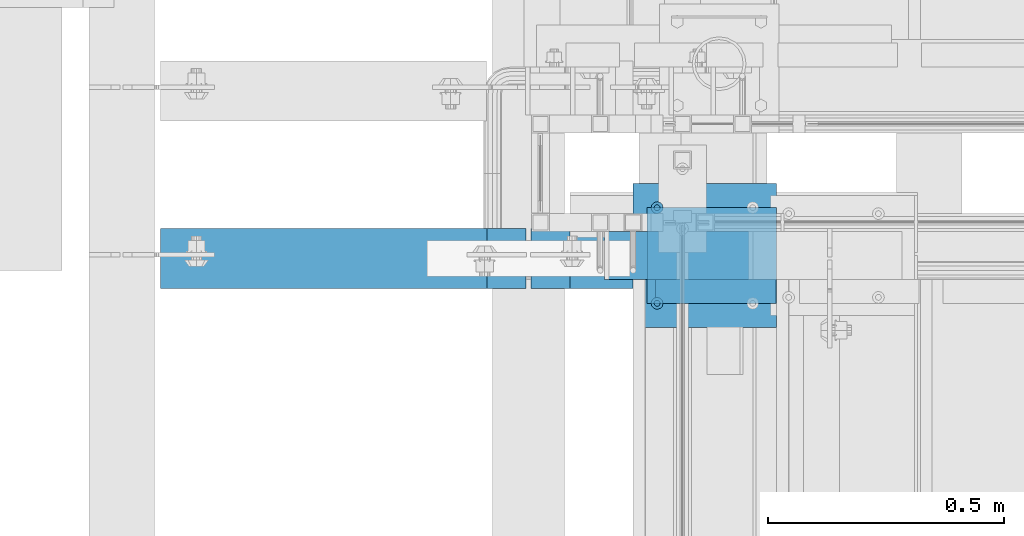
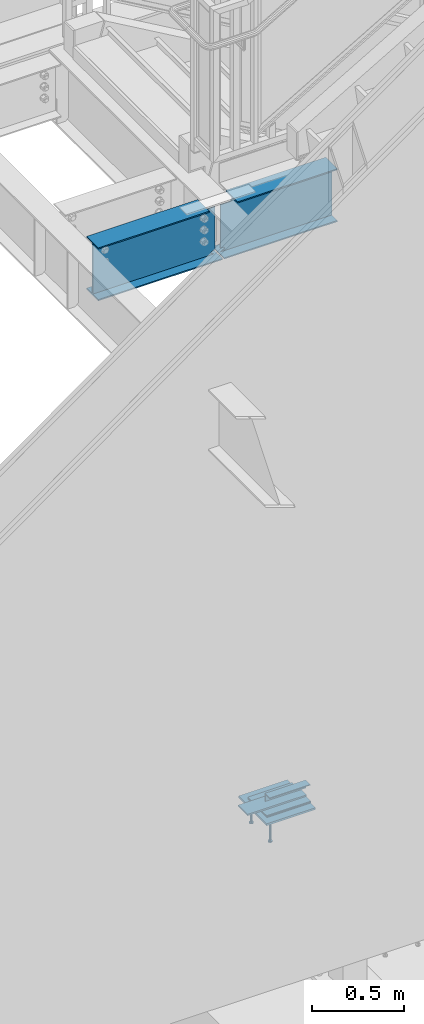
# One storey, part 910 of 1179: 10 beams, 7 elements without a shape of their own.
"""IFC2X3 building model written with IfcOpenShell, lengths in millimetres."""

from ifc_helpers import new_model, si_unit, frame, origin_with_axes, place, context, subcontext, project, spatial, faceted_brep, material, type_object, element, aggregate, save


model = new_model("IFC2X3")

# Units and contexts
model_context = context("Model", 3, precision=1e-05, world=origin_with_axes())
body_context = subcontext(model_context, "Body", "Model", "MODEL_VIEW")
ifc_project = project(units=[si_unit("LENGTHUNIT", "METRE", prefix="MILLI"), si_unit("AREAUNIT", "SQUARE_METRE"), si_unit("VOLUMEUNIT", "CUBIC_METRE"), si_unit("MASSUNIT", "GRAM", prefix="KILO"), si_unit("TIMEUNIT", "SECOND"), si_unit("PLANEANGLEUNIT", "RADIAN"), si_unit("SOLIDANGLEUNIT", "STERADIAN"), si_unit("THERMODYNAMICTEMPERATUREUNIT", "DEGREE_CELSIUS"), si_unit("LUMINOUSINTENSITYUNIT", "LUMEN")], contexts=[model_context])

# Site, building, storey
site_placement = place(None, origin_with_axes())
site = spatial("IfcSite", under=ifc_project, at=site_placement, CompositionType="ELEMENT")
building_placement = place(site_placement, origin_with_axes())
building = spatial("IfcBuilding", under=site, at=building_placement, Name="Undefined", CompositionType="ELEMENT")
storey_placement = place(building_placement, origin_with_axes())
storey = spatial("IfcBuildingStorey", under=building, at=storey_placement, Name="Undefined", CompositionType="ELEMENT", Elevation=0.0)

# Assembly, beam
assembly_1_placement = place(storey_placement, origin_with_axes())
assembly_1 = element("IfcElementAssembly", 1, at=assembly_1_placement, inside=storey, Name="STAIR", AssemblyPlace="NOTDEFINED", PredefinedType="RIGID_FRAME")
ifc_material_1 = material(Name="STEEL/A36")
beam_type_1 = type_object("IfcBeamType", Name="L2X2X3/16", PredefinedType="NOTDEFINED")
beam_1_placement = place(assembly_1_placement, frame((19548.8678269992, 39325.550000005, 97.6973832879577), z_axis=(0.0, -1.0, 0.0), x_axis=(1.0, 0.0, 0.0)))
beam_1 = element("IfcBeam", 2, at=beam_1_placement, type_object=beam_type_1, material=ifc_material_1, Name="ANGLE", ObjectType="L2X2X3/16", context=body_context, shape_type="Brep", body=[
    faceted_brep([(0.0, 25.3999999999996, -25.4000000000015), (0.0, 25.3999999999996, 25.4000000000015), (254.0, 25.3999999999996, 25.4000000000001), (254.0, 25.3999999999996, -25.4000000000001), (0.0, 20.6374999999998, 25.4000000000015), (254.0, 20.6374999999998, 25.4000000000001), (0.0, 20.6374999999998, -20.6374999999971), (254.0, 20.6374999999998, -20.6374999999998), (0.0, -25.3999999999996, -20.6374999999971), (254.0, -25.3999999999996, -20.6374999999998), (0.0, -25.3999999999996, -25.4000000000015), (254.0, -25.3999999999996, -25.4000000000001)], [[[0, 1, 2, 3]], [[1, 4, 5, 2]], [[4, 6, 7, 5]], [[6, 8, 9, 7]], [[8, 10, 11, 9]], [[10, 0, 3, 11]], [[5, 7, 9, 11, 3, 2]], [[10, 8, 6, 4, 1, 0]]]),
])

# Assembly, beams
assembly_2_placement = place(storey_placement, origin_with_axes())
assembly_2 = element("IfcElementAssembly", 3, at=assembly_2_placement, inside=storey, Name="EMBED", AssemblyPlace="NOTDEFINED", PredefinedType="RIGID_FRAME")
ifc_material_2 = material(Name="STEEL/A108")
beam_type_2 = type_object("IfcBeamType", Name="STUD_1/2-DIA", PredefinedType="NOTDEFINED")
beam_2_placement = place(assembly_2_placement, frame((19551.6500003795, 39300.1499999899, -12.6999999999998), z_axis=(0.0, -1.0, 0.0), x_axis=(0.0, 0.0, -1.0)))
beam_2 = element("IfcBeam", 4, at=beam_2_placement, type_object=beam_type_2, material=ifc_material_2, Name="SHEAR STUD", ObjectType="STUD_1/2-DIA", context=body_context, shape_type="Brep", body=[
    faceted_brep([(0.0, -3.1800000667572, 5.5), (0.0, -5.5, 3.1800000667572), (141.732, -5.5, 3.1800000667572), (141.732, -3.1800000667572, 5.5), (0.0, -6.34999999999854, 0.0), (141.732, -6.34999990463257, 0.0), (0.0, -5.5, -3.1800000667572), (141.732, -5.5, -3.1800000667572), (0.0, -3.1800000667572, -5.5), (141.732, -3.1800000667572, -5.5), (0.0, 0.0, -6.34999999999991), (141.732, 0.0, -6.34999990463257), (0.0, 3.1800000667572, -5.5), (141.732, 3.1800000667572, -5.5), (0.0, 5.5, -3.1800000667572), (141.732, 5.5, -3.1800000667572), (0.0, 6.34999999999854, 0.0), (141.732, 6.34999990463257, 0.0), (0.0, 5.5, 3.1800000667572), (141.732, 5.5, 3.1800000667572), (0.0, 3.1800000667572, 5.5), (141.732, 3.1800000667572, 5.5), (0.0, 0.0, 6.34999999999991), (141.732, 0.0, 6.34999990463257), (144.78, -10.9899997711182, 6.34999990463257), (144.78, -6.34000015258789, 10.9899997711182), (144.78, -12.6999998092651, 0.0), (144.78, -10.9899997711182, -6.34999990463257), (144.78, -6.34000015258789, -10.9899997711182), (144.78, 0.0, -12.6899995803833), (144.78, 6.34000015258789, -10.9899997711182), (144.78, 10.9899997711182, -6.34999990463257), (144.78, 12.6999998092651, 0.0), (144.78, 10.9899997711182, 6.34999990463257), (144.78, 6.34000015258789, 10.9899997711182), (144.78, 0.0, 12.6899995803833), (152.4, -10.9899997711182, 6.34999990463257), (152.4, -6.34000015258789, 10.9899997711182), (152.4, -12.6999998092651, 0.0), (152.4, -10.9899997711182, -6.34999990463257), (152.4, -6.34000015258789, -10.9899997711182), (152.4, 0.0, -12.6899995803833), (152.4, 6.34000015258789, -10.9899997711182), (152.4, 10.9899997711182, -6.34999990463257), (152.4, 12.6999998092651, 0.0), (152.4, 10.9899997711182, 6.34999990463257), (152.4, 6.34000015258789, 10.9899997711182), (152.4, 0.0, 12.6899995803833)], [[[0, 1, 2, 3]], [[1, 4, 5, 2]], [[4, 6, 7, 5]], [[6, 8, 9, 7]], [[8, 10, 11, 9]], [[10, 12, 13, 11]], [[12, 14, 15, 13]], [[14, 16, 17, 15]], [[16, 18, 19, 17]], [[18, 20, 21, 19]], [[20, 22, 23, 21]], [[22, 0, 3, 23]], [[22, 20, 18, 16, 14, 12, 10, 8, 6, 4, 1, 0]], [[3, 2, 24, 25]], [[2, 5, 26, 24]], [[5, 7, 27, 26]], [[7, 9, 28, 27]], [[9, 11, 29, 28]], [[11, 13, 30, 29]], [[13, 15, 31, 30]], [[15, 17, 32, 31]], [[17, 19, 33, 32]], [[19, 21, 34, 33]], [[21, 23, 35, 34]], [[23, 3, 25, 35]], [[25, 24, 36, 37]], [[24, 26, 38, 36]], [[26, 27, 39, 38]], [[27, 28, 40, 39]], [[28, 29, 41, 40]], [[29, 30, 42, 41]], [[30, 31, 43, 42]], [[31, 32, 44, 43]], [[32, 33, 45, 44]], [[33, 34, 46, 45]], [[34, 35, 47, 46]], [[35, 25, 37, 47]], [[38, 39, 40, 41, 42, 43, 44, 45, 46, 47, 37, 36]]]),
])
beam_3_placement = place(assembly_2_placement, frame((19551.6500003795, 39503.3499999899, -12.6999999999998), z_axis=(0.0, -1.0, 0.0), x_axis=(0.0, 0.0, -1.0)))
beam_3 = element("IfcBeam", 5, at=beam_3_placement, type_object=beam_type_2, material=ifc_material_2, Name="SHEAR STUD", ObjectType="STUD_1/2-DIA", context=body_context, shape_type="Brep", body=[
    faceted_brep([(0.0, -3.1800000667572, 5.5), (0.0, -5.5, 3.1800000667572), (141.732, -5.5, 3.1800000667572), (141.732, -3.1800000667572, 5.5), (0.0, -6.34999999999854, 0.0), (141.732, -6.34999990463257, 0.0), (0.0, -5.5, -3.1800000667572), (141.732, -5.5, -3.1800000667572), (0.0, -3.1800000667572, -5.5), (141.732, -3.1800000667572, -5.5), (0.0, 0.0, -6.34999999999991), (141.732, 0.0, -6.34999990463257), (0.0, 3.1800000667572, -5.5), (141.732, 3.1800000667572, -5.5), (0.0, 5.5, -3.1800000667572), (141.732, 5.5, -3.1800000667572), (0.0, 6.34999999999854, 0.0), (141.732, 6.34999990463257, 0.0), (0.0, 5.5, 3.1800000667572), (141.732, 5.5, 3.1800000667572), (0.0, 3.1800000667572, 5.5), (141.732, 3.1800000667572, 5.5), (0.0, 0.0, 6.34999999999991), (141.732, 0.0, 6.34999990463257), (144.78, -10.9899997711182, 6.34999990463257), (144.78, -6.34000015258789, 10.9899997711182), (144.78, -12.6999998092651, 0.0), (144.78, -10.9899997711182, -6.34999990463257), (144.78, -6.34000015258789, -10.9899997711182), (144.78, 0.0, -12.6899995803833), (144.78, 6.34000015258789, -10.9899997711182), (144.78, 10.9899997711182, -6.34999990463257), (144.78, 12.6999998092651, 0.0), (144.78, 10.9899997711182, 6.34999990463257), (144.78, 6.34000015258789, 10.9899997711182), (144.78, 0.0, 12.6899995803833), (152.4, -10.9899997711182, 6.34999990463257), (152.4, -6.34000015258789, 10.9899997711182), (152.4, -12.6999998092651, 0.0), (152.4, -10.9899997711182, -6.34999990463257), (152.4, -6.34000015258789, -10.9899997711182), (152.4, 0.0, -12.6899995803833), (152.4, 6.34000015258789, -10.9899997711182), (152.4, 10.9899997711182, -6.34999990463257), (152.4, 12.6999998092651, 0.0), (152.4, 10.9899997711182, 6.34999990463257), (152.4, 6.34000015258789, 10.9899997711182), (152.4, 0.0, 12.6899995803833)], [[[0, 1, 2, 3]], [[1, 4, 5, 2]], [[4, 6, 7, 5]], [[6, 8, 9, 7]], [[8, 10, 11, 9]], [[10, 12, 13, 11]], [[12, 14, 15, 13]], [[14, 16, 17, 15]], [[16, 18, 19, 17]], [[18, 20, 21, 19]], [[20, 22, 23, 21]], [[22, 0, 3, 23]], [[22, 20, 18, 16, 14, 12, 10, 8, 6, 4, 1, 0]], [[3, 2, 24, 25]], [[2, 5, 26, 24]], [[5, 7, 27, 26]], [[7, 9, 28, 27]], [[9, 11, 29, 28]], [[11, 13, 30, 29]], [[13, 15, 31, 30]], [[15, 17, 32, 31]], [[17, 19, 33, 32]], [[19, 21, 34, 33]], [[21, 23, 35, 34]], [[23, 3, 25, 35]], [[25, 24, 36, 37]], [[24, 26, 38, 36]], [[26, 27, 39, 38]], [[27, 28, 40, 39]], [[28, 29, 41, 40]], [[29, 30, 42, 41]], [[30, 31, 43, 42]], [[31, 32, 44, 43]], [[32, 33, 45, 44]], [[33, 34, 46, 45]], [[34, 35, 47, 46]], [[35, 25, 37, 47]], [[38, 39, 40, 41, 42, 43, 44, 45, 46, 47, 37, 36]]]),
])

# Beam
beam_type_3 = type_object("IfcBeamType", PredefinedType="NOTDEFINED")
beam_4_placement = place(assembly_1_placement, frame((19808.6121952611, 39401.7499999987, 17.5286833296634), z_axis=(0.0, -1.0, 0.0), x_axis=(-1.0, 0.0, 0.0)))
beam_4 = element("IfcBeam", 6, at=beam_4_placement, type_object=beam_type_3, material=ifc_material_1, Name="PLATE", context=body_context, shape_type="Brep", body=[
    faceted_brep([(0.0, 4.76249999999982, -50.7999999999993), (0.0, 4.76249999999982, 50.7999999999993), (368.087195261149, 4.76249999999948, 50.8000000000029), (368.087195261149, 4.76249999999948, -50.8000000000029), (0.0, -4.76249999999982, 50.7999999999993), (368.087195261145, -4.76250000000052, 50.8000000000029), (0.0, -4.76249999999982, -50.7999999999993), (368.087195261145, -4.76250000000052, -50.8000000000029)], [[[0, 1, 2, 3]], [[1, 4, 5, 2]], [[4, 6, 7, 5]], [[6, 0, 3, 7]], [[5, 7, 3, 2]], [[6, 4, 1, 0]]]),
])

aggregate(assembly_1, [beam_4, beam_1])

# Assembly, beam
assembly_3_placement = place(storey_placement, origin_with_axes())
assembly_3 = element("IfcElementAssembly", 7, at=assembly_3_placement, inside=storey, Name="LAYER", AssemblyPlace="NOTDEFINED", PredefinedType="RIGID_FRAME")
beam_type_4 = type_object("IfcBeamType", PredefinedType="NOTDEFINED")
beam_5_placement = place(assembly_3_placement, frame((19805.649492321, 39401.7499999899, 6.34963334067296), z_axis=(0.0, -1.0, 0.0), x_axis=(-1.0, 0.0, 0.0)))
beam_5 = element("IfcBeam", 8, at=beam_5_placement, type_object=beam_type_4, material=ifc_material_1, Name="LAYER", context=body_context, shape_type="Brep", body=[
    faceted_brep([(1.77351466845721e-11, 3.17500000001064, -101.600000000029), (0.0, 3.17500000000018, 101.599999999999), (275.436220746942, 3.17500000000001, 101.599999999999), (275.436220746942, 3.17500000000001, -101.599999999999), (0.0, -3.17500000000018, 101.599999999999), (275.436220746949, -3.17499999999999, 101.599999999999), (1.8644641386345e-11, -3.17499999998927, -101.600000000031), (275.436220746949, -3.17499999999999, -101.599999999999)], [[[0, 1, 2, 3]], [[1, 4, 5, 2]], [[4, 6, 7, 5]], [[6, 0, 3, 7]], [[5, 7, 3, 2]], [[6, 4, 1, 0]]]),
])
aggregate(assembly_3, [beam_5])

assembly_4_placement = place(storey_placement, origin_with_axes())
assembly_4 = element("IfcElementAssembly", 9, at=assembly_4_placement, inside=storey, Name="BEAM", AssemblyPlace="NOTDEFINED", PredefinedType="RIGID_FRAME")
ifc_material_3 = material(Name="STEEL/A992")
beam_type_5 = type_object("IfcBeamType", Name="W14X22", PredefinedType="NOTDEFINED")
beam_6_placement = place(assembly_4_placement, frame((19278.6, 39395.4000000093, 3927.475), z_axis=(0.0, 0.0, 1.0), x_axis=(1.0, 0.0, 0.0)))
beam_6 = element("IfcBeam", 10, at=beam_6_placement, type_object=beam_type_5, material=ifc_material_3, Name="BEAM", ObjectType="W14X22", context=body_context, shape_type="Brep", body=[
    faceted_brep([(16.6687500000044, -3.17500000000291, -142.907330326454), (16.6687500000044, 3.17500000000291, -142.907330326454), (37.7763095472983, 3.17500000000291, -143.332377915873), (37.7763095472983, -3.17500000000291, -143.332377915873), (42.0509977400034, 3.17500000000291, -146.840523853033), (42.0509977400034, -3.17500000000291, -146.840523853033), (24.6062500000044, -3.17500000000291, -166.3875), (24.6062500000044, 3.17500000000291, -166.3875), (16.6687500000044, 3.17500000000291, -166.3875), (16.6687500000044, -3.17500000000291, -166.3875), (37.7763096932795, -3.17500000000291, -160.932282657781), (37.7763096932795, 3.17500000000291, -160.932282657781), (42.0509977400034, -3.17500000000291, -157.42413636819), (42.0509977400034, 3.17500000000291, -157.42413636819), (43.6562496185325, -3.17500000000291, -152.132330110611), (43.6562496185325, 3.17500000000291, -152.132330110611), (711.199999999997, -63.5, 166.6875), (711.199999999997, -63.5, 174.625), (88.1062500000044, -63.5, 174.625), (88.1062500000044, -63.5, 166.6875), (711.199999999997, 63.5, 174.625), (88.1062500000044, 63.5, 174.625), (711.199999999997, 63.5, 166.6875), (88.1062500000044, 63.5, 166.6875), (711.199999999997, 3.17500000000291, 166.6875), (88.1062500000044, 3.17500000000291, 166.6875), (75.4062501907392, -3.17500000000291, 142.875000000076), (75.4062501907392, 3.17500000000291, 142.875000000076), (16.6687500000007, 3.17500000000291, 142.875), (16.6687500000007, -3.17500000000291, 142.875), (80.2663297087856, -3.17500000000291, 143.841729922664), (80.2663297087856, 3.17500000000291, 143.841729922664), (84.3865061769393, -3.17500000000291, 146.594743823142), (84.3865061769393, 3.17500000000291, 146.594743823142), (87.1395200774168, -3.17500000000291, 150.714920291296), (87.1395200774168, 3.17500000000291, 150.714920291296), (88.1062500000044, -3.17500000000291, 155.574999809341), (88.1062500000044, 3.17500000000291, 155.574999809341), (88.1062500000044, -3.17500000000291, 166.6875), (711.199999999997, -3.17500000000291, 166.6875), (16.6687500000044, 3.17500000000291, -166.6875), (711.199999999997, 3.17500000000291, -166.6875), (711.199999999997, 63.5, -166.6875), (16.6687500000044, 63.5, -166.6875), (5.55625000000509, 63.5, -166.6875), (5.55625000000509, 3.17500000000291, -166.6875), (711.199999999997, -63.5, -174.625), (711.199999999997, -63.5, -166.6875), (16.6687500000044, -63.5, -166.6875), (5.55625000000509, -63.5, -166.6875), (5.55625000000509, -63.5, -174.625), (711.199999999997, 63.5, -174.625), (5.55625000000509, 63.5, -174.625), (711.199999999997, -3.17500000000291, -166.6875), (16.6687500000044, -3.17500000000291, -166.6875), (5.55625000000509, -3.17500000000291, -166.6875)], [[[0, 1, 2, 3]], [[3, 2, 4, 5]], [[6, 7, 8, 9]], [[10, 11, 7, 6]], [[12, 13, 11, 10]], [[14, 15, 13, 12]], [[5, 4, 15, 14]], [[16, 17, 18, 19]], [[17, 20, 21, 18]], [[20, 22, 23, 21]], [[22, 24, 25, 23]], [[26, 27, 28, 29]], [[30, 31, 27, 26]], [[32, 33, 31, 30]], [[34, 35, 33, 32]], [[36, 37, 35, 34]], [[18, 21, 23, 25, 37, 36, 38, 19]], [[39, 16, 19, 38]], [[40, 41, 42, 43, 44, 45]], [[46, 47, 48, 49, 50]], [[51, 46, 50, 52]], [[43, 42, 51, 52, 44]], [[41, 24, 22, 20, 17, 16, 39, 53, 47, 46, 51, 42]], [[48, 47, 53, 54, 55, 49]], [[44, 52, 50, 49, 55, 45]], [[54, 40, 45, 55]], [[40, 54, 9, 8]], [[2, 1, 28, 27, 31, 33, 35, 37, 25, 24, 41, 40, 8, 7, 11, 13, 15, 4]], [[29, 28, 1, 0]], [[10, 6, 9, 54, 53, 39, 38, 36, 34, 32, 30, 26, 29, 0, 3, 5, 14, 12]]]),
])
aggregate(assembly_4, [beam_6])

assembly_5_placement = place(storey_placement, origin_with_axes())
assembly_5 = element("IfcElementAssembly", 11, at=assembly_5_placement, inside=storey, Name="BEAM", AssemblyPlace="NOTDEFINED", PredefinedType="RIGID_FRAME")
beam_7_placement = place(assembly_5_placement, frame((18415.0, 39395.4000000093, 3927.475), z_axis=(0.0, 0.0, 1.0), x_axis=(1.0, 0.0, 0.0)))
beam_7 = element("IfcBeam", 12, at=beam_7_placement, type_object=beam_type_5, material=ifc_material_3, Name="BEAM", ObjectType="W14X22", context=body_context, shape_type="Brep", body=[
    faceted_brep([(846.931249999998, -3.17500000000291, -166.3875), (846.931249999998, 3.17500000000291, -166.3875), (838.993749999998, 3.17500000000291, -166.3875), (838.993749999998, -3.17500000000291, -166.3875), (825.823690306723, 3.17500000000291, -160.932282657781), (825.823690306723, -3.17500000000291, -160.932282657781), (821.549002259999, 3.17500000000291, -157.42413636819), (821.549002259999, -3.17500000000291, -157.42413636819), (819.94375038147, 3.17500000000291, -152.132330110611), (819.94375038147, -3.17500000000291, -152.132330110611), (821.549002259999, 3.17500000000291, -146.840523853033), (821.549002259999, -3.17500000000291, -146.840523853033), (825.823690452704, 3.17500000000291, -143.332377915873), (825.823690452704, -3.17500000000291, -143.332377915873), (846.931249999998, -3.17500000000291, -142.907330326454), (846.931249999998, 3.17500000000291, -142.907330326454), (82.5499999999993, 3.17500000000291, 166.6875), (82.5499999999993, 63.5, 166.6875), (775.493749999998, 63.5, 166.6875), (775.493749999998, 3.17500000000291, 166.6875), (82.5499999999993, -63.5, -174.625), (82.5499999999993, 63.5, -174.625), (858.043749999997, 63.5, -174.625), (858.043749999997, -63.5, -174.625), (846.931249999998, -63.5, -166.6875), (82.5499999999993, -63.5, -166.6875), (858.043749999997, -63.5, -166.6875), (846.931249999998, -3.17500000000291, -166.6875), (82.5499999999993, -3.17500000000291, -166.6875), (858.043749999997, -3.17500000000291, -166.6875), (846.931249999998, 63.5, -166.6875), (82.5499999999993, 63.5, -166.6875), (82.5499999999993, 3.17500000000291, -166.6875), (846.931249999998, 3.17500000000291, -166.6875), (858.043749999997, 3.17500000000291, -166.6875), (858.043749999997, 63.5, -166.6875), (82.5499999999993, -3.17500000000291, 166.6875), (82.5499999999993, -63.5, 166.6875), (82.5499999999993, -63.5, 174.625), (82.5499999999993, 63.5, 174.625), (775.493749999998, -3.17500000000291, 166.6875), (775.493749999998, -63.5, 166.6875), (775.493749999998, -63.5, 174.625), (775.493749999998, 63.5, 174.625), (775.493749999998, -3.17500000000291, 155.574999809468), (775.493749999998, 3.17500000000291, 155.574999809468), (776.460479922585, -3.17500000000291, 150.714920291423), (776.460479922585, 3.17500000000291, 150.714920291423), (779.213493823063, -3.17500000000291, 146.594743823269), (779.213493823063, 3.17500000000291, 146.594743823269), (783.333670291217, -3.17500000000291, 143.841729922791), (783.333670291217, 3.17500000000291, 143.841729922791), (788.193749809263, -3.17500000000291, 142.875000000203), (788.193749809263, 3.17500000000291, 142.875000000203), (846.931249999998, -3.17500000000291, 142.875000000203), (846.931249999998, 3.17500000000291, 142.875000000203)], [[[0, 1, 2, 3]], [[3, 2, 4, 5]], [[5, 4, 6, 7]], [[7, 6, 8, 9]], [[9, 8, 10, 11]], [[11, 10, 12, 13]], [[14, 13, 12, 15]], [[16, 17, 18, 19]], [[20, 21, 22, 23]], [[24, 25, 20, 23, 26]], [[27, 28, 25, 24, 26, 29]], [[30, 31, 32, 33, 34, 35]], [[29, 34, 33, 27]], [[26, 23, 22, 35, 34, 29]], [[21, 31, 30, 35, 22]], [[20, 25, 28, 36, 37, 38, 39, 17, 16, 32, 31, 21]], [[37, 36, 40, 41]], [[38, 37, 41, 42]], [[39, 38, 42, 43]], [[17, 39, 43, 18]], [[42, 41, 40, 44, 45, 19, 18, 43]], [[46, 47, 45, 44]], [[48, 49, 47, 46]], [[50, 51, 49, 48]], [[52, 53, 51, 50]], [[53, 52, 54, 55]], [[55, 54, 14, 15]], [[10, 8, 6, 4, 2, 1, 33, 32, 16, 19, 45, 47, 49, 51, 53, 55, 15, 12]], [[27, 33, 1, 0]], [[54, 52, 50, 48, 46, 44, 40, 36, 28, 27, 0, 3, 5, 7, 9, 11, 13, 14]]]),
])
aggregate(assembly_5, [beam_7])

assembly_6_placement = place(storey_placement, origin_with_axes())
assembly_6 = element("IfcElementAssembly", 13, at=assembly_6_placement, inside=storey, Name="LAYER", AssemblyPlace="NOTDEFINED", PredefinedType="RIGID_FRAME")
beam_type_6 = type_object("IfcBeamType", PredefinedType="NOTDEFINED")
beam_8_placement = place(assembly_6_placement, frame((19805.6497463503, 39401.7499999899, 11.1784999999995), z_axis=(0.0, -1.0, 0.0), x_axis=(-1.0, 0.0, 0.0)))
beam_8 = element("IfcBeam", 14, at=beam_8_placement, type_object=beam_type_6, material=ifc_material_1, Name="LAYER", context=body_context, shape_type="Brep", body=[
    faceted_brep([(0.0, 1.5875, -101.6), (0.0, 1.5875, 101.6), (275.436220746942, 1.58750000000001, 101.599999999999), (275.436220746942, 1.58750000000001, -101.599999999999), (0.0, -1.5875, 101.6), (275.436220746946, -1.58749999999999, 101.599999999999), (0.0, -1.5875, -101.6), (275.436220746946, -1.58749999999999, -101.599999999999)], [[[0, 1, 2, 3]], [[1, 4, 5, 2]], [[4, 6, 7, 5]], [[6, 0, 3, 7]], [[5, 7, 3, 2]], [[6, 4, 1, 0]]]),
])
aggregate(assembly_6, [beam_8])

assembly_7_placement = place(storey_placement, origin_with_axes())
assembly_7 = element("IfcElementAssembly", 15, at=assembly_7_placement, inside=storey, Name="LAYER", AssemblyPlace="NOTDEFINED", PredefinedType="RIGID_FRAME")
beam_9_placement = place(assembly_7_placement, frame((19805.6497463503, 39401.7499999899, 1.58731667033634), z_axis=(0.0, -1.0, 0.0), x_axis=(-1.0, 0.0, 0.0)))
beam_9 = element("IfcBeam", 16, at=beam_9_placement, type_object=beam_type_6, material=ifc_material_1, Name="LAYER", context=body_context, shape_type="Brep", body=[
    faceted_brep([(0.0, 1.5875, -101.6), (0.0, 1.5875, 101.6), (275.436220746942, 1.58750000000001, 101.599999999999), (275.436220746942, 1.58750000000001, -101.599999999999), (0.0, -1.5875, 101.6), (275.436220746946, -1.58749999999999, 101.599999999999), (0.0, -1.5875, -101.6), (275.436220746946, -1.58749999999999, -101.599999999999)], [[[0, 1, 2, 3]], [[1, 4, 5, 2]], [[4, 6, 7, 5]], [[6, 0, 3, 7]], [[5, 7, 3, 2]], [[6, 4, 1, 0]]]),
])
aggregate(assembly_7, [beam_9])

# Beam
beam_type_7 = type_object("IfcBeamType", PredefinedType="NOTDEFINED")
beam_10_placement = place(assembly_2_placement, frame((19805.6500003795, 39401.7499999899, -6.35), z_axis=(0.0, 1.0, 0.0), x_axis=(-1.0, 0.0, 0.0)))
beam_10 = element("IfcBeam", 17, at=beam_10_placement, type_object=beam_type_7, material=ifc_material_1, Name="EMBED", context=body_context, shape_type="Brep", body=[
    faceted_brep([(0.0, 6.35, -152.400000000001), (0.0, 6.34999999999854, 152.400000000001), (304.799999999999, 6.35, 152.400000000001), (304.799999999999, 6.35, -152.400000000001), (0.0, -6.34999999999854, 152.400000000001), (304.799999999999, -6.35, 152.400000000001), (0.0, -6.35, -152.400000000001), (304.799999999999, -6.35, -152.400000000001)], [[[0, 1, 2, 3]], [[1, 4, 5, 2]], [[4, 6, 7, 5]], [[6, 0, 3, 7]], [[5, 7, 3, 2]], [[6, 4, 1, 0]]]),
])

aggregate(assembly_2, [beam_2, beam_3, beam_10])

save(model, "model.ifc")
